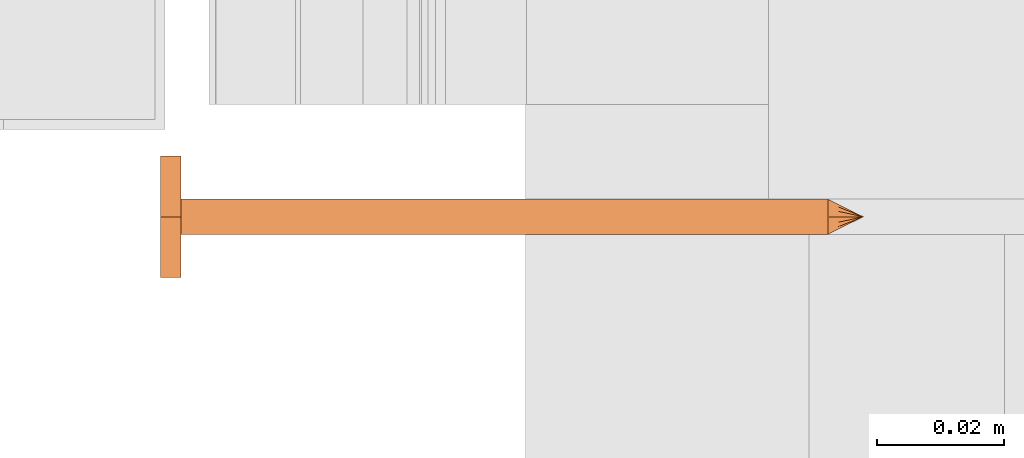
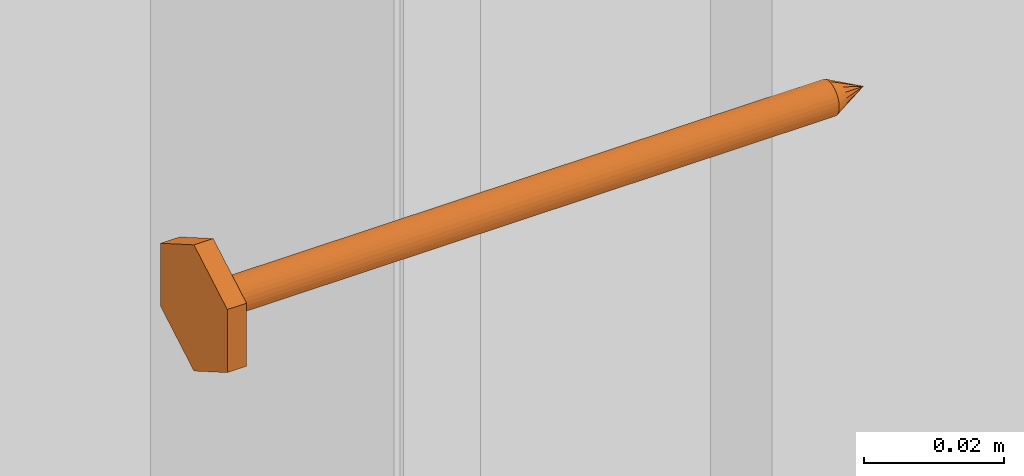
# One storey, part 19 of 44: 1 proxy.
"""IFC4 building model written with IfcOpenShell, lengths in feet."""

from ifc_helpers import new_model, entity, si_unit, converted_unit, derived_unit, direction, frame, origin, place, context, subcontext, project, spatial, source, transform, mapped, material, type_object, type_shapes, element, save


model = new_model("IFC4")

# Units and contexts
model_context = context("Model", 3, precision=0.0001, world=origin(), true_north=direction((6.12303176911189e-17, 1.0)))
body_context = subcontext(model_context, "Body", "Model", "MODEL_VIEW")
ifc_project = project(units=[converted_unit("LENGTHUNIT", "FOOT", entity("IfcRatioMeasure", 0.3048), si_unit("LENGTHUNIT", "METRE"), dimensions=[1, 0, 0, 0, 0, 0, 0]), converted_unit("AREAUNIT", "SQUARE FOOT", entity("IfcRatioMeasure", 0.09290304), si_unit("AREAUNIT", "SQUARE_METRE"), dimensions=[2, 0, 0, 0, 0, 0, 0]), converted_unit("VOLUMEUNIT", "CUBIC FOOT", entity("IfcRatioMeasure", 0.028316846592), si_unit("VOLUMEUNIT", "CUBIC_METRE"), dimensions=[3, 0, 0, 0, 0, 0, 0]), converted_unit("PLANEANGLEUNIT", "DEGREE", entity("IfcRatioMeasure", 0.0174532925199433), si_unit("PLANEANGLEUNIT", "RADIAN"), dimensions=[0, 0, 0, 0, 0, 0, 0]), si_unit("MASSUNIT", "GRAM", prefix="KILO"), derived_unit("MASSDENSITYUNIT", [(si_unit("MASSUNIT", "GRAM", prefix="KILO"), 1), (si_unit("LENGTHUNIT", "METRE"), -3)]), derived_unit("MOMENTOFINERTIAUNIT", [(si_unit("LENGTHUNIT", "METRE"), 4)]), si_unit("TIMEUNIT", "SECOND"), si_unit("FREQUENCYUNIT", "HERTZ"), si_unit("THERMODYNAMICTEMPERATUREUNIT", "DEGREE_CELSIUS"), derived_unit("THERMALTRANSMITTANCEUNIT", [(si_unit("MASSUNIT", "GRAM", prefix="KILO"), 1), (si_unit("THERMODYNAMICTEMPERATUREUNIT", "KELVIN"), -1), (si_unit("TIMEUNIT", "SECOND"), -3)]), derived_unit("VOLUMETRICFLOWRATEUNIT", [(si_unit("LENGTHUNIT", "METRE"), 3), (si_unit("TIMEUNIT", "SECOND"), -1)]), si_unit("ELECTRICCURRENTUNIT", "AMPERE"), si_unit("ELECTRICVOLTAGEUNIT", "VOLT"), si_unit("POWERUNIT", "WATT"), si_unit("FORCEUNIT", "NEWTON"), si_unit("ILLUMINANCEUNIT", "LUX"), si_unit("LUMINOUSFLUXUNIT", "LUMEN"), si_unit("LUMINOUSINTENSITYUNIT", "CANDELA"), derived_unit("USERDEFINED", [(si_unit("MASSUNIT", "GRAM", prefix="KILO"), -1), (si_unit("LENGTHUNIT", "METRE"), -2), (si_unit("TIMEUNIT", "SECOND"), 3), (si_unit("LUMINOUSFLUXUNIT", "LUMEN"), 1)]), derived_unit("LINEARVELOCITYUNIT", [(si_unit("LENGTHUNIT", "METRE"), 1), (si_unit("TIMEUNIT", "SECOND"), -1)]), si_unit("PRESSUREUNIT", "PASCAL"), derived_unit("USERDEFINED", [(si_unit("LENGTHUNIT", "METRE"), -2), (si_unit("MASSUNIT", "GRAM", prefix="KILO"), 1), (si_unit("TIMEUNIT", "SECOND"), -2)]), derived_unit("LINEARFORCEUNIT", [(si_unit("MASSUNIT", "GRAM", prefix="KILO"), 1), (si_unit("LENGTHUNIT", "METRE"), 1), (si_unit("TIMEUNIT", "SECOND"), -2), (si_unit("LENGTHUNIT", "METRE"), -1)]), derived_unit("PLANARFORCEUNIT", [(si_unit("MASSUNIT", "GRAM", prefix="KILO"), 1), (si_unit("LENGTHUNIT", "METRE"), 1), (si_unit("TIMEUNIT", "SECOND"), -2), (si_unit("LENGTHUNIT", "METRE"), -2)])], contexts=[model_context])

# Site, building, storey
site_placement = place(None, origin())
site = spatial("IfcSite", under=ifc_project, at=site_placement, CompositionType="ELEMENT")
building_placement = place(site_placement, origin())
building = spatial("IfcBuilding", under=site, at=building_placement, CompositionType="ELEMENT")
storey_placement = place(building_placement, origin())
storey = spatial("IfcBuildingStorey", under=building, at=storey_placement, CompositionType="ELEMENT", Elevation=0.0)

# Proxy
ifc_material = material(Name="STRONG-DRIVE TIMBER SCREW (EXTERIOR GRADE)", Category="Materials")
building_element_proxy_type = type_object("IfcBuildingElementProxyType", PredefinedType="NOTDEFINED", material=ifc_material)
cartesian_point_1 = entity("IfcCartesianPoint", [0.0, -0.00916666666677942, -0.333333333333231])
vertex_point_1 = entity("IfcVertexPoint", cartesian_point_1)
cartesian_point_2 = entity("IfcCartesianPoint", [0.0, 0.00916666666667798, -0.333333333333232])
vertex_point_2 = entity("IfcVertexPoint", cartesian_point_2)
cartesian_point_3 = entity("IfcCartesianPoint", [0.0, 0.0, -0.333333333333232])
ifc_direction_1 = entity("IfcDirection", [0.0, 0.0, 1.0])
ifc_direction_2 = entity("IfcDirection", [0.0, 1.0, 0.0])
edge_curve_1 = entity("IfcEdgeCurve", vertex_point_1, vertex_point_2, entity("IfcTrimmedCurve", entity("IfcCircle", entity("IfcAxis2Placement3D", cartesian_point_3, ifc_direction_1, ifc_direction_2), 0.0091666666667287), [cartesian_point_1], [cartesian_point_2], True, "CARTESIAN"), True)
vertex_point_3 = entity("IfcVertexPoint", cartesian_point_3)
ifc_direction_3 = entity("IfcDirection", [0.0, -1.0, 0.0])
edge_curve_2 = entity("IfcEdgeCurve", vertex_point_2, vertex_point_3, entity("IfcTrimmedCurve", entity("IfcLine", cartesian_point_2, entity("IfcVector", ifc_direction_3, 1.0)), [cartesian_point_2], [cartesian_point_3], True, "CARTESIAN"), True)
edge_curve_3 = entity("IfcEdgeCurve", vertex_point_3, vertex_point_1, entity("IfcTrimmedCurve", entity("IfcLine", cartesian_point_3, entity("IfcVector", ifc_direction_3, 1.0)), [cartesian_point_3], [cartesian_point_1], True, "CARTESIAN"), True)
edge_curve_4 = entity("IfcEdgeCurve", vertex_point_2, vertex_point_1, entity("IfcTrimmedCurve", entity("IfcCircle", entity("IfcAxis2Placement3D", cartesian_point_3, ifc_direction_1, ifc_direction_2), 0.0091666666667287), [cartesian_point_2], [cartesian_point_1], True, "CARTESIAN"), True)
cartesian_point_4 = entity("IfcCartesianPoint", [0.0, 0.0, -0.351666666666333])
vertex_point_4 = entity("IfcVertexPoint", cartesian_point_4)
edge_curve_5 = entity("IfcEdgeCurve", vertex_point_4, vertex_point_2, entity("IfcTrimmedCurve", entity("IfcLine", cartesian_point_4, entity("IfcVector", entity("IfcDirection", [0.0, 0.447213595507238, 0.894427190996276]), 1.0)), [cartesian_point_4], [cartesian_point_2], True, "CARTESIAN"), True)
edge_curve_6 = entity("IfcEdgeCurve", vertex_point_1, vertex_point_4, entity("IfcTrimmedCurve", entity("IfcLine", cartesian_point_1, entity("IfcVector", entity("IfcDirection", [0.0, 0.447213595507224, -0.894427190996283]), 1.0)), [cartesian_point_1], [cartesian_point_4], True, "CARTESIAN"), True)
cartesian_point_5 = entity("IfcCartesianPoint", [-0.00916666666669726, 0.0, -0.333333333333231])
cartesian_point_6 = entity("IfcCartesianPoint", [0.0, 0.0, -0.338202184590857])
ifc_direction_4 = entity("IfcDirection", [0.0, 0.0, -1.0])
cartesian_point_7 = entity("IfcCartesianPoint", [-0.0312499999999625, 0.0180421959120341, 0.0104166666670403])
vertex_point_5 = entity("IfcVertexPoint", cartesian_point_7)
cartesian_point_8 = entity("IfcCartesianPoint", [-0.0312499999999625, -0.0180421959123371, 0.0104166666670405])
vertex_point_6 = entity("IfcVertexPoint", cartesian_point_8)
ifc_direction_5 = entity("IfcDirection", [0.0, -1.0, 0.0])
edge_curve_7 = entity("IfcEdgeCurve", vertex_point_5, vertex_point_6, entity("IfcTrimmedCurve", entity("IfcLine", cartesian_point_7, entity("IfcVector", ifc_direction_5, 1.0)), [cartesian_point_7], [cartesian_point_8], True, "CARTESIAN"), True)
cartesian_point_9 = entity("IfcCartesianPoint", [0.0, -0.0360843918245031, 0.0104166666670406])
vertex_point_7 = entity("IfcVertexPoint", cartesian_point_9)
edge_curve_8 = entity("IfcEdgeCurve", vertex_point_6, vertex_point_7, entity("IfcTrimmedCurve", entity("IfcLine", cartesian_point_8, entity("IfcVector", entity("IfcDirection", [0.866025403784438, -0.500000000000001, 0.0]), 1.0)), [cartesian_point_8], [cartesian_point_9], True, "CARTESIAN"), True)
cartesian_point_10 = entity("IfcCartesianPoint", [0.0312500000000785, -0.0180421959122939, 0.0104166666670405])
vertex_point_8 = entity("IfcVertexPoint", cartesian_point_10)
edge_curve_9 = entity("IfcEdgeCurve", vertex_point_7, vertex_point_8, entity("IfcTrimmedCurve", entity("IfcLine", cartesian_point_9, entity("IfcVector", entity("IfcDirection", [0.86602540378444, 0.499999999999998, 0.0]), 1.0)), [cartesian_point_9], [cartesian_point_10], True, "CARTESIAN"), True)
cartesian_point_11 = entity("IfcCartesianPoint", [0.0312500000000786, 0.0180421959119906, 0.0104166666670403])
vertex_point_9 = entity("IfcVertexPoint", cartesian_point_11)
ifc_direction_6 = entity("IfcDirection", [0.0, 1.0, 0.0])
edge_curve_10 = entity("IfcEdgeCurve", vertex_point_8, vertex_point_9, entity("IfcTrimmedCurve", entity("IfcLine", cartesian_point_10, entity("IfcVector", ifc_direction_6, 1.0)), [cartesian_point_10], [cartesian_point_11], True, "CARTESIAN"), True)
cartesian_point_12 = entity("IfcCartesianPoint", [0.0, 0.0360843918242001, 0.0104166666670402])
vertex_point_10 = entity("IfcVertexPoint", cartesian_point_12)
edge_curve_11 = entity("IfcEdgeCurve", vertex_point_9, vertex_point_10, entity("IfcTrimmedCurve", entity("IfcLine", cartesian_point_11, entity("IfcVector", entity("IfcDirection", [-0.866025403784436, 0.500000000000004, 0.0]), 1.0)), [cartesian_point_11], [cartesian_point_12], True, "CARTESIAN"), True)
edge_curve_12 = entity("IfcEdgeCurve", vertex_point_10, vertex_point_5, entity("IfcTrimmedCurve", entity("IfcLine", cartesian_point_12, entity("IfcVector", entity("IfcDirection", [-0.866025403784438, -0.500000000000001, 0.0]), 1.0)), [cartesian_point_12], [cartesian_point_7], True, "CARTESIAN"), True)
ifc_direction_7 = entity("IfcDirection", [0.0, 0.0, 1.0])
cartesian_point_13 = entity("IfcCartesianPoint", [-0.0312499999999625, 0.018042195912034, 0.0])
vertex_point_11 = entity("IfcVertexPoint", cartesian_point_13)
cartesian_point_14 = entity("IfcCartesianPoint", [0.0, 0.0360843918242001, 0.0])
vertex_point_12 = entity("IfcVertexPoint", cartesian_point_14)
edge_curve_13 = entity("IfcEdgeCurve", vertex_point_11, vertex_point_12, entity("IfcTrimmedCurve", entity("IfcLine", cartesian_point_13, entity("IfcVector", entity("IfcDirection", [0.866025403784438, 0.500000000000001, 0.0]), 1.0)), [cartesian_point_13], [cartesian_point_14], True, "CARTESIAN"), True)
cartesian_point_15 = entity("IfcCartesianPoint", [0.0312500000000786, 0.0180421959119905, 0.0])
vertex_point_13 = entity("IfcVertexPoint", cartesian_point_15)
edge_curve_14 = entity("IfcEdgeCurve", vertex_point_12, vertex_point_13, entity("IfcTrimmedCurve", entity("IfcLine", cartesian_point_14, entity("IfcVector", entity("IfcDirection", [0.866025403784437, -0.500000000000004, 0.0]), 1.0)), [cartesian_point_14], [cartesian_point_15], True, "CARTESIAN"), True)
cartesian_point_16 = entity("IfcCartesianPoint", [0.0312500000000785, -0.0180421959122939, 0.0])
vertex_point_14 = entity("IfcVertexPoint", cartesian_point_16)
edge_curve_15 = entity("IfcEdgeCurve", vertex_point_13, vertex_point_14, entity("IfcTrimmedCurve", entity("IfcLine", cartesian_point_15, entity("IfcVector", ifc_direction_5, 1.0)), [cartesian_point_15], [cartesian_point_16], True, "CARTESIAN"), True)
cartesian_point_17 = entity("IfcCartesianPoint", [0.0, -0.0360843918245032, 0.0])
vertex_point_15 = entity("IfcVertexPoint", cartesian_point_17)
edge_curve_16 = entity("IfcEdgeCurve", vertex_point_14, vertex_point_15, entity("IfcTrimmedCurve", entity("IfcLine", cartesian_point_16, entity("IfcVector", entity("IfcDirection", [-0.86602540378444, -0.499999999999998, 0.0]), 1.0)), [cartesian_point_16], [cartesian_point_17], True, "CARTESIAN"), True)
cartesian_point_18 = entity("IfcCartesianPoint", [-0.0312499999999625, -0.0180421959123372, 0.0])
vertex_point_16 = entity("IfcVertexPoint", cartesian_point_18)
edge_curve_17 = entity("IfcEdgeCurve", vertex_point_15, vertex_point_16, entity("IfcTrimmedCurve", entity("IfcLine", cartesian_point_17, entity("IfcVector", entity("IfcDirection", [-0.866025403784438, 0.500000000000001, 0.0]), 1.0)), [cartesian_point_17], [cartesian_point_18], True, "CARTESIAN"), True)
edge_curve_18 = entity("IfcEdgeCurve", vertex_point_16, vertex_point_11, entity("IfcTrimmedCurve", entity("IfcLine", cartesian_point_18, entity("IfcVector", ifc_direction_6, 1.0)), [cartesian_point_18], [cartesian_point_13], True, "CARTESIAN"), True)
ifc_direction_8 = entity("IfcDirection", [0.0, 0.0, -1.0])
edge_curve_19 = entity("IfcEdgeCurve", vertex_point_5, vertex_point_11, entity("IfcTrimmedCurve", entity("IfcLine", cartesian_point_7, entity("IfcVector", ifc_direction_8, 1.0)), [cartesian_point_7], [cartesian_point_13], True, "CARTESIAN"), True)
edge_curve_20 = entity("IfcEdgeCurve", vertex_point_16, vertex_point_6, entity("IfcTrimmedCurve", entity("IfcLine", cartesian_point_8, entity("IfcVector", ifc_direction_7, 1.0)), [cartesian_point_18], [cartesian_point_8], True, "CARTESIAN"), True)
edge_curve_21 = entity("IfcEdgeCurve", vertex_point_15, vertex_point_7, entity("IfcTrimmedCurve", entity("IfcLine", cartesian_point_9, entity("IfcVector", ifc_direction_7, 1.0)), [cartesian_point_17], [cartesian_point_9], True, "CARTESIAN"), True)
edge_curve_22 = entity("IfcEdgeCurve", vertex_point_14, vertex_point_8, entity("IfcTrimmedCurve", entity("IfcLine", cartesian_point_10, entity("IfcVector", ifc_direction_7, 1.0)), [cartesian_point_16], [cartesian_point_10], True, "CARTESIAN"), True)
edge_curve_23 = entity("IfcEdgeCurve", vertex_point_13, vertex_point_9, entity("IfcTrimmedCurve", entity("IfcLine", cartesian_point_11, entity("IfcVector", ifc_direction_7, 1.0)), [cartesian_point_15], [cartesian_point_11], True, "CARTESIAN"), True)
edge_curve_24 = entity("IfcEdgeCurve", vertex_point_12, vertex_point_10, entity("IfcTrimmedCurve", entity("IfcLine", cartesian_point_12, entity("IfcVector", ifc_direction_7, 1.0)), [cartesian_point_14], [cartesian_point_12], True, "CARTESIAN"), True)
cartesian_point_19 = entity("IfcCartesianPoint", [0.0, -0.00916666666682102, 0.0])
vertex_point_17 = entity("IfcVertexPoint", cartesian_point_19)
cartesian_point_20 = entity("IfcCartesianPoint", [0.0, 0.00916666666651231, 0.0])
vertex_point_18 = entity("IfcVertexPoint", cartesian_point_20)
cartesian_point_21 = entity("IfcCartesianPoint", [0.0, 0.0, 0.0])
ifc_direction_9 = entity("IfcDirection", [0.0, 0.0, 1.0])
ifc_direction_10 = entity("IfcDirection", [0.0, 1.0, 0.0])
edge_curve_25 = entity("IfcEdgeCurve", vertex_point_17, vertex_point_18, entity("IfcTrimmedCurve", entity("IfcCircle", entity("IfcAxis2Placement3D", cartesian_point_21, ifc_direction_9, ifc_direction_10), 0.00916666666666667), [cartesian_point_19], [cartesian_point_20], True, "CARTESIAN"), True)
edge_curve_26 = entity("IfcEdgeCurve", vertex_point_18, vertex_point_17, entity("IfcTrimmedCurve", entity("IfcCircle", entity("IfcAxis2Placement3D", cartesian_point_21, ifc_direction_9, ifc_direction_10), 0.00916666666666667), [cartesian_point_20], [cartesian_point_19], True, "CARTESIAN"), True)
cartesian_point_22 = entity("IfcCartesianPoint", [0.0, -0.00916666666682389, -0.333333333333339])
vertex_point_19 = entity("IfcVertexPoint", cartesian_point_22)
cartesian_point_23 = entity("IfcCartesianPoint", [0.0, 0.00916666666650944, -0.333333333333339])
vertex_point_20 = entity("IfcVertexPoint", cartesian_point_23)
cartesian_point_24 = entity("IfcCartesianPoint", [0.0, 0.0, -0.333333333333339])
ifc_direction_11 = entity("IfcDirection", [0.0, 0.0, -1.0])
edge_curve_27 = entity("IfcEdgeCurve", vertex_point_19, vertex_point_20, entity("IfcTrimmedCurve", entity("IfcCircle", entity("IfcAxis2Placement3D", cartesian_point_24, ifc_direction_11, ifc_direction_10), 0.00916666666666667), [cartesian_point_22], [cartesian_point_23], True, "CARTESIAN"), True)
edge_curve_28 = entity("IfcEdgeCurve", vertex_point_20, vertex_point_19, entity("IfcTrimmedCurve", entity("IfcCircle", entity("IfcAxis2Placement3D", cartesian_point_24, ifc_direction_11, ifc_direction_10), 0.00916666666666667), [cartesian_point_23], [cartesian_point_22], True, "CARTESIAN"), True)
edge_curve_29 = entity("IfcEdgeCurve", vertex_point_17, vertex_point_19, entity("IfcTrimmedCurve", entity("IfcLine", cartesian_point_19, entity("IfcVector", ifc_direction_11, 1.0)), [cartesian_point_19], [cartesian_point_22], True, "CARTESIAN"), True)
edge_curve_30 = entity("IfcEdgeCurve", vertex_point_20, vertex_point_18, entity("IfcTrimmedCurve", entity("IfcLine", cartesian_point_20, entity("IfcVector", ifc_direction_9, 1.0)), [cartesian_point_23], [cartesian_point_20], True, "CARTESIAN"), True)
shared_shape = source(origin(), body_context, "Body", "AdvancedBrep", [
    entity("IfcAdvancedBrep", entity("IfcClosedShell", [entity("IfcAdvancedFace", [entity("IfcFaceOuterBound", entity("IfcEdgeLoop", [entity("IfcOrientedEdge", None, None, edge_curve_1, True), entity("IfcOrientedEdge", None, None, edge_curve_2, True), entity("IfcOrientedEdge", None, None, edge_curve_3, True)]), True)], entity("IfcPlane", entity("IfcAxis2Placement3D", cartesian_point_3, ifc_direction_1, ifc_direction_2)), True), entity("IfcAdvancedFace", [entity("IfcFaceOuterBound", entity("IfcEdgeLoop", [entity("IfcOrientedEdge", None, None, edge_curve_4, True), entity("IfcOrientedEdge", None, None, edge_curve_3, False), entity("IfcOrientedEdge", None, None, edge_curve_2, False)]), True)], entity("IfcPlane", entity("IfcAxis2Placement3D", cartesian_point_3, ifc_direction_1, ifc_direction_2)), True), entity("IfcAdvancedFace", [entity("IfcFaceOuterBound", entity("IfcEdgeLoop", [entity("IfcOrientedEdge", None, None, edge_curve_5, True), entity("IfcOrientedEdge", None, None, edge_curve_1, False), entity("IfcOrientedEdge", None, None, edge_curve_6, True)]), True)], entity("IfcSurfaceOfRevolution", entity("IfcArbitraryOpenProfileDef", "CURVE", None, entity("IfcTrimmedCurve", entity("IfcLine", cartesian_point_4, entity("IfcVector", entity("IfcDirection", [0.447213595507221, 0.0, -0.894427190996284]), 1.0)), [cartesian_point_5], [cartesian_point_4], True, "CARTESIAN")), None, entity("IfcAxis1Placement", cartesian_point_6, ifc_direction_4)), True), entity("IfcAdvancedFace", [entity("IfcFaceOuterBound", entity("IfcEdgeLoop", [entity("IfcOrientedEdge", None, None, edge_curve_6, False), entity("IfcOrientedEdge", None, None, edge_curve_4, False), entity("IfcOrientedEdge", None, None, edge_curve_5, False)]), True)], entity("IfcSurfaceOfRevolution", entity("IfcArbitraryOpenProfileDef", "CURVE", None, entity("IfcTrimmedCurve", entity("IfcLine", cartesian_point_4, entity("IfcVector", entity("IfcDirection", [0.447213595507221, 0.0, -0.894427190996284]), 1.0)), [cartesian_point_5], [cartesian_point_4], True, "CARTESIAN")), None, entity("IfcAxis1Placement", cartesian_point_6, ifc_direction_4)), True)])),
    entity("IfcAdvancedBrep", entity("IfcClosedShell", [entity("IfcAdvancedFace", [entity("IfcFaceOuterBound", entity("IfcEdgeLoop", [entity("IfcOrientedEdge", None, None, edge_curve_7, True), entity("IfcOrientedEdge", None, None, edge_curve_8, True), entity("IfcOrientedEdge", None, None, edge_curve_9, True), entity("IfcOrientedEdge", None, None, edge_curve_10, True), entity("IfcOrientedEdge", None, None, edge_curve_11, True), entity("IfcOrientedEdge", None, None, edge_curve_12, True)]), True)], entity("IfcPlane", entity("IfcAxis2Placement3D", cartesian_point_7, ifc_direction_7, ifc_direction_5)), True), entity("IfcAdvancedFace", [entity("IfcFaceOuterBound", entity("IfcEdgeLoop", [entity("IfcOrientedEdge", None, None, edge_curve_13, True), entity("IfcOrientedEdge", None, None, edge_curve_14, True), entity("IfcOrientedEdge", None, None, edge_curve_15, True), entity("IfcOrientedEdge", None, None, edge_curve_16, True), entity("IfcOrientedEdge", None, None, edge_curve_17, True), entity("IfcOrientedEdge", None, None, edge_curve_18, True)]), True)], entity("IfcPlane", entity("IfcAxis2Placement3D", cartesian_point_13, ifc_direction_8, ifc_direction_6)), True), entity("IfcAdvancedFace", [entity("IfcFaceOuterBound", entity("IfcEdgeLoop", [entity("IfcOrientedEdge", None, None, edge_curve_7, False), entity("IfcOrientedEdge", None, None, edge_curve_19, True), entity("IfcOrientedEdge", None, None, edge_curve_18, False), entity("IfcOrientedEdge", None, None, edge_curve_20, True)]), True)], entity("IfcPlane", entity("IfcAxis2Placement3D", cartesian_point_7, entity("IfcDirection", [-1.0, 0.0, 0.0]), ifc_direction_8)), True), entity("IfcAdvancedFace", [entity("IfcFaceOuterBound", entity("IfcEdgeLoop", [entity("IfcOrientedEdge", None, None, edge_curve_8, False), entity("IfcOrientedEdge", None, None, edge_curve_20, False), entity("IfcOrientedEdge", None, None, edge_curve_17, False), entity("IfcOrientedEdge", None, None, edge_curve_21, True)]), True)], entity("IfcPlane", entity("IfcAxis2Placement3D", cartesian_point_8, entity("IfcDirection", [-0.500000000000001, -0.866025403784438, 0.0]), ifc_direction_8)), True), entity("IfcAdvancedFace", [entity("IfcFaceOuterBound", entity("IfcEdgeLoop", [entity("IfcOrientedEdge", None, None, edge_curve_9, False), entity("IfcOrientedEdge", None, None, edge_curve_21, False), entity("IfcOrientedEdge", None, None, edge_curve_16, False), entity("IfcOrientedEdge", None, None, edge_curve_22, True)]), True)], entity("IfcPlane", entity("IfcAxis2Placement3D", cartesian_point_9, entity("IfcDirection", [0.499999999999998, -0.86602540378444, 0.0]), ifc_direction_8)), True), entity("IfcAdvancedFace", [entity("IfcFaceOuterBound", entity("IfcEdgeLoop", [entity("IfcOrientedEdge", None, None, edge_curve_10, False), entity("IfcOrientedEdge", None, None, edge_curve_22, False), entity("IfcOrientedEdge", None, None, edge_curve_15, False), entity("IfcOrientedEdge", None, None, edge_curve_23, True)]), True)], entity("IfcPlane", entity("IfcAxis2Placement3D", cartesian_point_10, entity("IfcDirection", [1.0, 0.0, 0.0]), ifc_direction_8)), True), entity("IfcAdvancedFace", [entity("IfcFaceOuterBound", entity("IfcEdgeLoop", [entity("IfcOrientedEdge", None, None, edge_curve_11, False), entity("IfcOrientedEdge", None, None, edge_curve_23, False), entity("IfcOrientedEdge", None, None, edge_curve_14, False), entity("IfcOrientedEdge", None, None, edge_curve_24, True)]), True)], entity("IfcPlane", entity("IfcAxis2Placement3D", cartesian_point_11, entity("IfcDirection", [0.500000000000003, 0.866025403784437, 0.0]), ifc_direction_8)), True), entity("IfcAdvancedFace", [entity("IfcFaceOuterBound", entity("IfcEdgeLoop", [entity("IfcOrientedEdge", None, None, edge_curve_12, False), entity("IfcOrientedEdge", None, None, edge_curve_24, False), entity("IfcOrientedEdge", None, None, edge_curve_13, False), entity("IfcOrientedEdge", None, None, edge_curve_19, False)]), True)], entity("IfcPlane", entity("IfcAxis2Placement3D", cartesian_point_12, entity("IfcDirection", [-0.500000000000001, 0.866025403784438, 0.0]), ifc_direction_8)), True)])),
    entity("IfcAdvancedBrep", entity("IfcClosedShell", [entity("IfcAdvancedFace", [entity("IfcFaceOuterBound", entity("IfcEdgeLoop", [entity("IfcOrientedEdge", None, None, edge_curve_25, True), entity("IfcOrientedEdge", None, None, edge_curve_26, True)]), True)], entity("IfcPlane", entity("IfcAxis2Placement3D", cartesian_point_20, ifc_direction_9, entity("IfcDirection", [-1.0, 0.0, 0.0]))), True), entity("IfcAdvancedFace", [entity("IfcFaceOuterBound", entity("IfcEdgeLoop", [entity("IfcOrientedEdge", None, None, edge_curve_27, True), entity("IfcOrientedEdge", None, None, edge_curve_28, True)]), True)], entity("IfcPlane", entity("IfcAxis2Placement3D", cartesian_point_23, ifc_direction_11, entity("IfcDirection", [1.0, 0.0, 0.0]))), True), entity("IfcAdvancedFace", [entity("IfcFaceOuterBound", entity("IfcEdgeLoop", [entity("IfcOrientedEdge", None, None, edge_curve_25, False), entity("IfcOrientedEdge", None, None, edge_curve_29, True), entity("IfcOrientedEdge", None, None, edge_curve_28, False), entity("IfcOrientedEdge", None, None, edge_curve_30, True)]), True)], entity("IfcCylindricalSurface", entity("IfcAxis2Placement3D", cartesian_point_24, ifc_direction_9, ifc_direction_10), 0.00916666666666667), True), entity("IfcAdvancedFace", [entity("IfcFaceOuterBound", entity("IfcEdgeLoop", [entity("IfcOrientedEdge", None, None, edge_curve_26, False), entity("IfcOrientedEdge", None, None, edge_curve_30, False), entity("IfcOrientedEdge", None, None, edge_curve_27, False), entity("IfcOrientedEdge", None, None, edge_curve_29, False)]), True)], entity("IfcCylindricalSurface", entity("IfcAxis2Placement3D", cartesian_point_24, ifc_direction_9, ifc_direction_10), 0.00916666666666667), True)])),
])
type_shapes(building_element_proxy_type, [shared_shape])
proxy_placement = place(storey_placement, frame((1459.13314342118, 1.94204634015957, 10.2519890161991), z_axis=(-1.0, 0.0, 0.0), x_axis=(0.0, 1.0, 0.0)))
element("IfcBuildingElementProxy", 1, at=proxy_placement, inside=storey, type_object=building_element_proxy_type, material=ifc_material, PredefinedType="NOTDEFINED", context=body_context, shape_type="MappedRepresentation", body=[
    mapped(shared_shape, transform((0.0, 0.0, 0.0), scale=1.0)),
])

save(model, "model.ifc")
